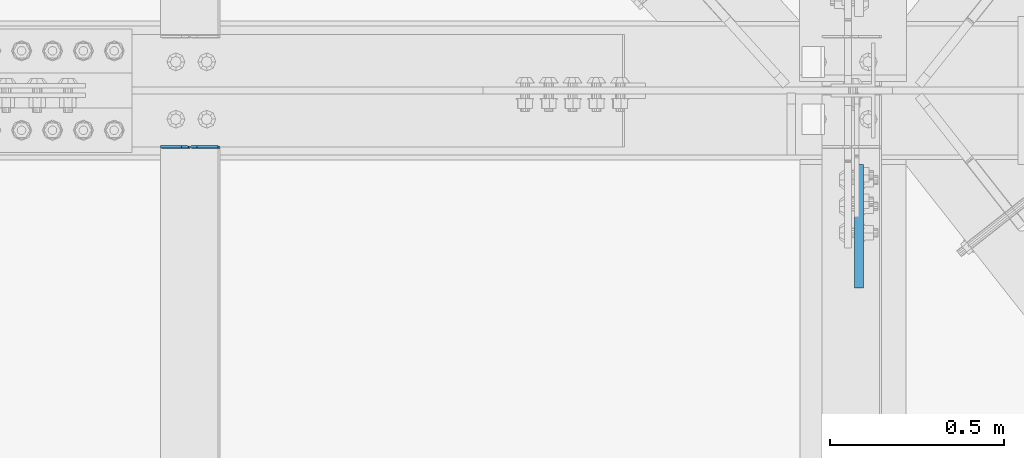
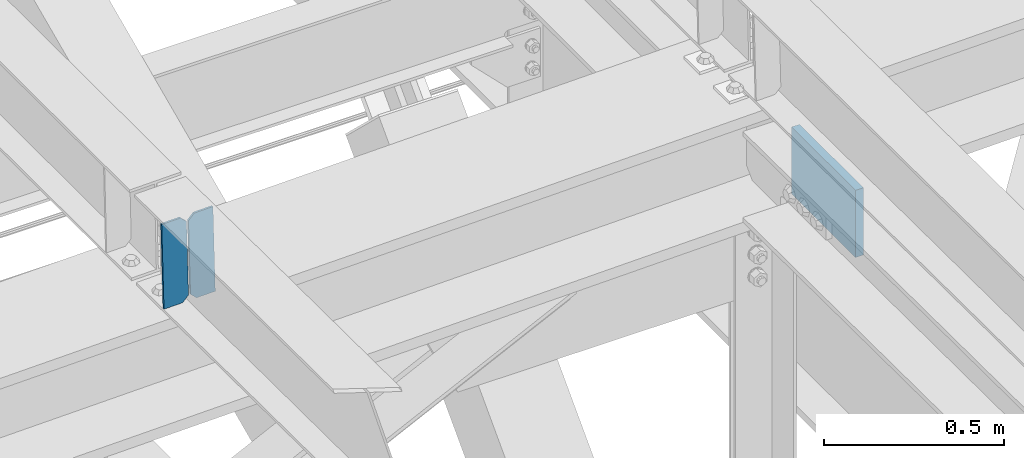
# One storey, part 3486 of 3843: 3 plates, 2 elements without a shape of their own.
"""IFC2X3 building model written with IfcOpenShell, lengths in millimetres."""

from ifc_helpers import new_model, si_unit, frame, origin_with_axes, place, context, subcontext, project, spatial, faceted_brep, material, type_object, element, aggregate, save


model = new_model("IFC2X3")

# Units and contexts
model_context = context("Model", 3, precision=1e-05, world=origin_with_axes())
body_context = subcontext(model_context, "Body", "Model", "MODEL_VIEW")
ifc_project = project(units=[si_unit("LENGTHUNIT", "METRE", prefix="MILLI"), si_unit("AREAUNIT", "SQUARE_METRE"), si_unit("VOLUMEUNIT", "CUBIC_METRE"), si_unit("MASSUNIT", "GRAM", prefix="KILO"), si_unit("TIMEUNIT", "SECOND"), si_unit("PLANEANGLEUNIT", "RADIAN"), si_unit("SOLIDANGLEUNIT", "STERADIAN"), si_unit("THERMODYNAMICTEMPERATUREUNIT", "DEGREE_CELSIUS"), si_unit("LUMINOUSINTENSITYUNIT", "LUMEN")], contexts=[model_context])

# Site, building, storey
site_placement = place(None, origin_with_axes())
site = spatial("IfcSite", under=ifc_project, at=site_placement, CompositionType="ELEMENT")
building_placement = place(site_placement, origin_with_axes())
building = spatial("IfcBuilding", under=site, at=building_placement, Name="Undefined", CompositionType="ELEMENT")
storey_placement = place(building_placement, origin_with_axes())
storey = spatial("IfcBuildingStorey", under=building, at=storey_placement, Name="Undefined", CompositionType="ELEMENT", Elevation=0.0)

# Assembly, plates
assembly_1_placement = place(storey_placement, origin_with_axes())
assembly_1 = element("IfcElementAssembly", 1, at=assembly_1_placement, inside=storey, Name="BEAM", AssemblyPlace="NOTDEFINED", PredefinedType="RIGID_FRAME")
ifc_material = material(Name="STEEL/A572-50")
plate_type_1 = type_object("IfcPlateType", PredefinedType="NOTDEFINED")
plate_1_placement = place(assembly_1_placement, frame((68433.6964818837, 83820.8500166435, 46120.1153274109), z_axis=(-0.0211520975258318, 0.00782754699832003, 0.999745626786258), x_axis=(-0.999776269357428, -0.0001656340000621, -0.0211514490075981)))
plate_1 = element("IfcPlate", 2, at=plate_1_placement, type_object=plate_type_1, material=ifc_material, Name="PLATE", context=body_context, shape_type="Brep", body=[
    faceted_brep([(0.0, -3.17499999999927, 0.0), (6.83940015733242e-10, -3.17499999996653, 288.924999998613), (6.54836185276508e-10, 3.17500000001746, 288.924999998591), (0.0, 3.17499999999927, 0.0), (60.3250007643655, -3.17500000017753, 288.924999998606), (60.3250007643219, 3.17499999979918, 288.924999998584), (79.3750000013097, -3.17500000025029, 269.875000761494), (79.375000001266, 3.17499999972642, 269.875000761487), (79.375000000713, -3.17500000026484, 19.0499992370605), (79.3750000006985, 3.17499999971187, 19.0499992370533), (60.325000763667, -3.17500000020664, -1.45519152283669e-11), (60.3250007636234, 3.17499999977736, -3.63797880709171e-11)], [[[0, 1, 2, 3]], [[1, 4, 5, 2]], [[4, 6, 7, 5]], [[6, 8, 9, 7]], [[8, 10, 11, 9]], [[10, 0, 3, 11]], [[5, 7, 9, 11, 3, 2]], [[10, 8, 6, 4, 1, 0]]]),
])
plate_2_placement = place(assembly_1_placement, frame((68347.9906611925, 83820.8358176616, 46118.3021194051), z_axis=(-0.0211520975258318, 0.00782754699832003, 0.999745626786258), x_axis=(-0.999776269357428, -0.0001656340000621, -0.0211514490075981)))
plate_2 = element("IfcPlate", 3, at=plate_2_placement, type_object=plate_type_1, material=ifc_material, Name="PLATE", context=body_context, shape_type="Brep", body=[
    faceted_brep([(4.36557456851006e-11, -3.17499999998836, 19.0499992370969), (6.11180439591408e-10, -3.17499999996653, 269.875000761516), (5.96628524363041e-10, 3.17500000001746, 269.875000761502), (1.45519152283669e-11, 3.17499999998836, 19.0499992370824), (19.0499992376572, -3.17500000003201, 288.924999998606), (19.0499992376281, 3.1749999999447, 288.924999998584), (79.3750000013242, -3.17500000025029, 288.924999998591), (79.3750000013097, 3.1749999997337, 288.92499999857), (79.3750000006548, -3.17500000026484, -2.18278728425503e-11), (79.3750000006403, 3.17499999969732, -2.91038304567337e-11), (19.0499992370023, -3.17500000005384, 0.0), (19.0499992369587, 3.17499999992287, -1.45519152283669e-11)], [[[0, 1, 2, 3]], [[1, 4, 5, 2]], [[4, 6, 7, 5]], [[6, 8, 9, 7]], [[8, 10, 11, 9]], [[10, 0, 3, 11]], [[5, 7, 9, 11, 3, 2]], [[10, 8, 6, 4, 1, 0]]]),
])
aggregate(assembly_1, [plate_1, plate_2])

# Assembly, plate
assembly_2_placement = place(storey_placement, origin_with_axes())
assembly_2 = element("IfcElementAssembly", 4, at=assembly_2_placement, inside=storey, Name="BEAM", AssemblyPlace="NOTDEFINED", PredefinedType="RIGID_FRAME")
plate_type_2 = type_object("IfcPlateType", PredefinedType="NOTDEFINED")
plate_3_placement = place(assembly_2_placement, frame((70273.8624914684, 83416.7750001047, 45837.9644133035), z_axis=(0.0, 1.0, 0.0), x_axis=(0.0, 0.0, 1.0)))
plate_3 = element("IfcPlate", 5, at=plate_3_placement, type_object=plate_type_2, material=ifc_material, Name="PLATE", context=body_context, shape_type="Brep", body=[
    faceted_brep([(0.0, -12.6999999999971, 0.0), (0.0147141397246742, -12.7000000013795, 355.599999695551), (0.0147141397246742, 12.6999999986292, 355.599999695653), (0.0, 12.6999999999971, 0.0), (228.599998464349, -12.7000000013795, 355.599999691767), (228.599998464349, 12.6999999986292, 355.599999691869), (228.585197689645, -12.6999999999825, -2.18278728425503e-10), (228.585197689645, 12.7000000000116, -1.16415321826935e-10)], [[[0, 1, 2, 3]], [[1, 4, 5, 2]], [[4, 6, 7, 5]], [[6, 0, 3, 7]], [[5, 7, 3, 2]], [[6, 4, 1, 0]]]),
])
aggregate(assembly_2, [plate_3])

save(model, "model.ifc")
